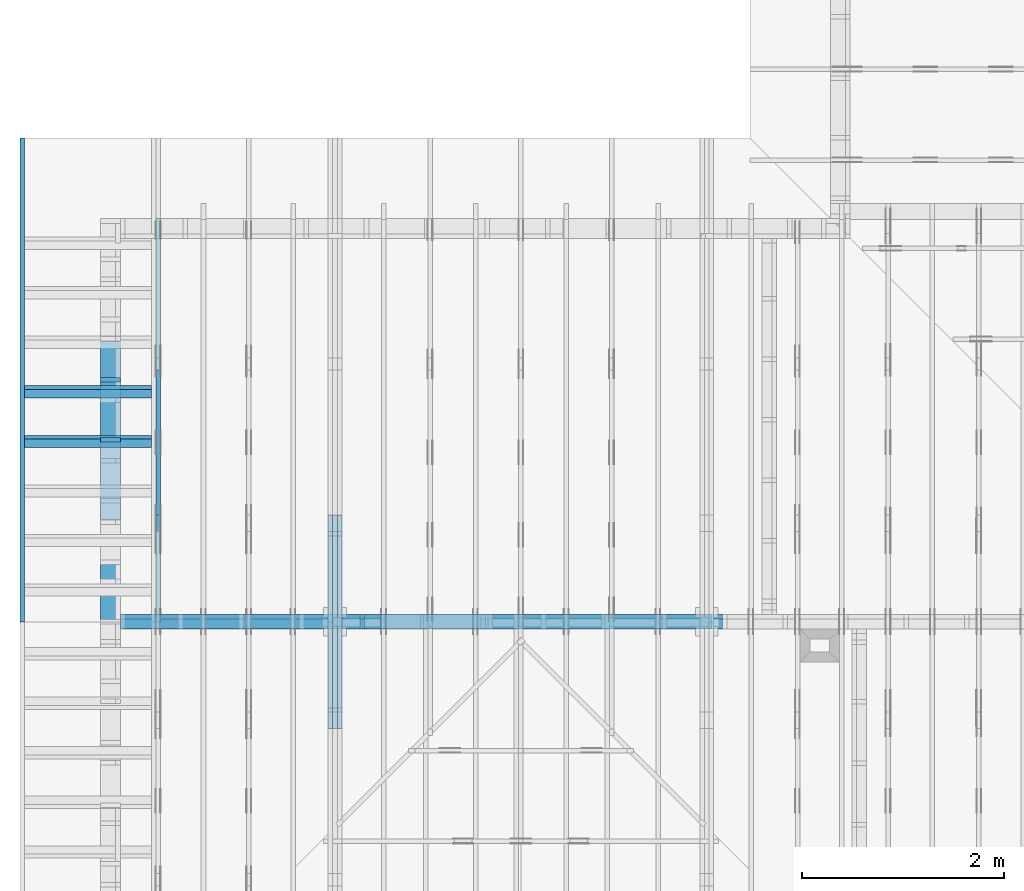
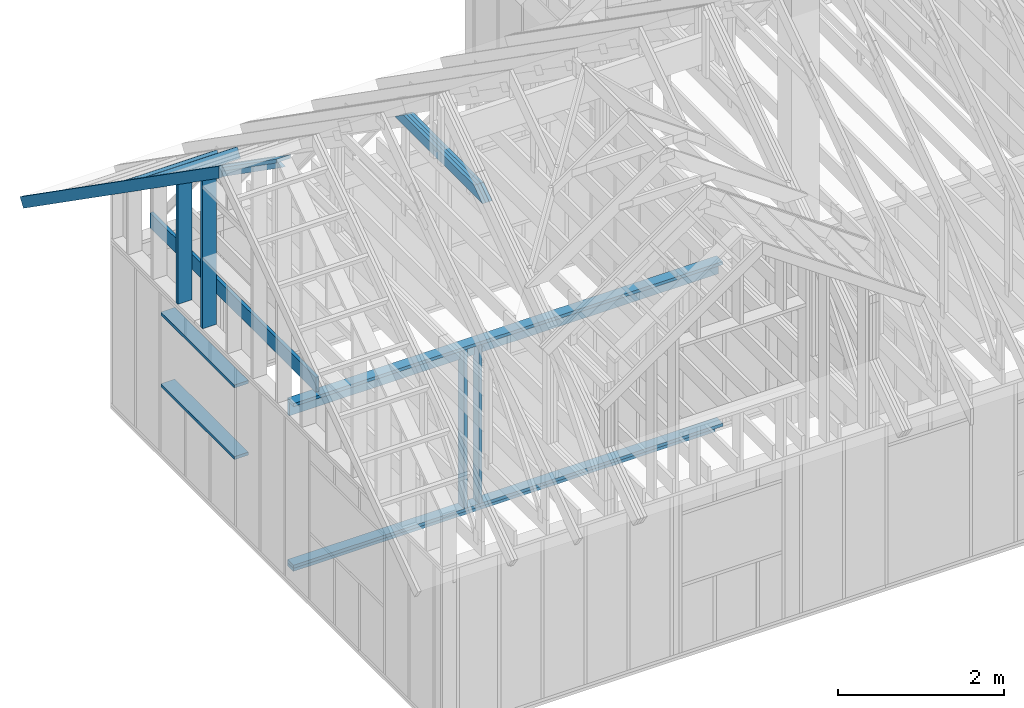
# One storey, part 12 of 70: 19 members, 6 elements without a shape of their own.
"""IFC2X3 building model written with IfcOpenShell, lengths in millimetres."""

from ifc_helpers import new_model, si_unit, frame, origin, origin_with_axes, origin_2d, place, context, project, spatial, faceted_brep, element, aggregate, save


model = new_model("IFC2X3")

# Units and contexts
model_context = context("Model", 3, precision=1e-05, world=origin())
plan_context = context("Plan", 2, precision=1e-05, world=origin_2d())
ifc_project = project(units=[si_unit("LENGTHUNIT", "METRE", prefix="MILLI"), si_unit("AREAUNIT", "SQUARE_METRE"), si_unit("VOLUMEUNIT", "CUBIC_METRE"), si_unit("SOLIDANGLEUNIT", "STERADIAN"), si_unit("PLANEANGLEUNIT", "RADIAN"), si_unit("MASSUNIT", "GRAM"), si_unit("TIMEUNIT", "SECOND"), si_unit("THERMODYNAMICTEMPERATUREUNIT", "DEGREE_CELSIUS"), si_unit("LUMINOUSINTENSITYUNIT", "LUMEN")], contexts=[model_context, plan_context])

# Site, building, storey
site_placement = place(None, origin_with_axes())
site = spatial("IfcSite", under=ifc_project, at=site_placement, CompositionType="ELEMENT")
building_placement = place(site_placement, origin_with_axes())
building = spatial("IfcBuilding", under=site, at=building_placement, Name="Layout 1", CompositionType="ELEMENT")
storey_placement = place(building_placement, origin_with_axes())
storey = spatial("IfcBuildingStorey", under=building, at=storey_placement, Name="Storey 1", CompositionType="ELEMENT", Elevation=0.0)

# Assembly, members
assembly_1_placement = place(storey_placement, frame((1969.9999999999982, 8000.000000000001, 1.1021457184401395e-14), z_axis=(-1.0, 1.836909530733566e-16, 6.123031769111886e-17), x_axis=(-1.836909530733566e-16, -1.0, 0.0)))
assembly_1 = element("IfcElementAssembly", 1, at=assembly_1_placement, inside=storey, Name="T11", AssemblyPlace="FACTORY", PredefinedType="TRUSS")
member_1_placement = place(assembly_1_placement, frame((5060.798502586593, 2964.999999998785, -90.0), z_axis=(0.0, 0.0, 1.0), x_axis=(-1.0, 1.2246063538223773e-16, 0.0)))
member_1 = element("IfcMember", 2, at=member_1_placement, Name="C1", context=model_context, shape_type="Brep", body=[
    faceted_brep([(2121.597005175296, 145.00000000000728, 45.0), (0.0, 145.00000000000728, 45.0), (207.08146097743884, 0.0, 45.0), (1914.5155441979737, 0.0, 45.0), (0.0, 145.00000000000728, 0.0), (2121.597005175296, 145.00000000000728, 2.5981211727881944e-13), (1914.5155441979737, 0.0, 2.3445278999165447e-13), (207.08146097743884, 0.0, 2.5359327287179227e-14), (207.08146097743878, -7.105427357601002e-14, 3.1554436208840472e-30), (207.08146097743878, -7.105427357601002e-14, 45.0), (1.4210854715202004e-14, 145.00000000000728, 45.0), (1.4210854715202004e-14, 145.00000000000728, 0.0), (1914.5155441979737, 7.26803319922997e-12, 4.8521444511629875e-31), (1914.5155441979737, 7.27078856352607e-12, 45.0), (207.08146097743884, 1.898228698049977e-15, 45.0), (207.08146097743884, -8.571355980503717e-16, 5.248268497299439e-32), (2121.597005175296, 145.00000000000728, 0.0), (2121.597005175296, 145.00000000000728, 45.0), (1914.515544197974, 7.389644451905042e-12, 45.0), (1914.515544197974, 7.389644451905042e-12, 1.262177448353619e-29), (0.0, 145.00000000000728, 0.0), (-1.6871183120499046e-31, 145.00000000000728, 45.0), (2121.597005175296, 145.00000000000713, 45.0), (2121.597005175296, 145.00000000000713, -7.888609052210118e-30)], [[[0, 1, 2, 3]], [[4, 5, 6, 7]], [[8, 9, 10, 11]], [[12, 13, 14, 15]], [[16, 17, 18, 19]], [[20, 21, 22, 23]]]),
])
member_2_placement = place(assembly_1_placement, frame((5060.798502586593, 2964.999999998785, -135.0), z_axis=(0.0, 0.0, 1.0), x_axis=(-1.0, 1.2246063538223773e-16, 0.0)))
member_2 = element("IfcMember", 3, at=member_2_placement, Name="C1", context=model_context, shape_type="Brep", body=[
    faceted_brep([(2121.597005175296, 145.00000000000728, 45.0), (0.0, 145.00000000000728, 45.0), (207.08146097743884, 0.0, 45.0), (1914.5155441979737, 0.0, 45.0), (0.0, 145.00000000000728, 0.0), (2121.597005175296, 145.00000000000728, 2.5981211727881944e-13), (1914.5155441979737, 0.0, 2.3445278999165447e-13), (207.08146097743884, 0.0, 2.5359327287179227e-14), (207.08146097743878, -7.105427357601002e-14, 3.1554436208840472e-30), (207.08146097743878, -7.105427357601002e-14, 45.0), (1.4210854715202004e-14, 145.00000000000728, 45.0), (1.4210854715202004e-14, 145.00000000000728, 0.0), (1914.5155441979737, 7.26803319922997e-12, 4.8521444511629875e-31), (1914.5155441979737, 7.27078856352607e-12, 45.0), (207.08146097743884, 1.898228698049977e-15, 45.0), (207.08146097743884, -8.571355980503717e-16, 5.248268497299439e-32), (2121.597005175296, 145.00000000000728, 0.0), (2121.597005175296, 145.00000000000728, 45.0), (1914.515544197974, 7.389644451905042e-12, 45.0), (1914.515544197974, 7.389644451905042e-12, 1.262177448353619e-29), (0.0, 145.00000000000728, 0.0), (-1.6871183120499046e-31, 145.00000000000728, 45.0), (2121.597005175296, 145.00000000000713, 45.0), (2121.597005175296, 145.00000000000713, -7.888609052210118e-30)], [[[0, 1, 2, 3]], [[4, 5, 6, 7]], [[8, 9, 10, 11]], [[12, 13, 14, 15]], [[16, 17, 18, 19]], [[20, 21, 22, 23]]]),
])
member_3_placement = place(assembly_1_placement, frame((5060.798502586593, 2964.999999998785, -180.0), z_axis=(0.0, 0.0, 1.0), x_axis=(-1.0, 1.2246063538223773e-16, 0.0)))
member_3 = element("IfcMember", 4, at=member_3_placement, Name="C1", context=model_context, shape_type="Brep", body=[
    faceted_brep([(2121.597005175296, 145.00000000000728, 45.0), (0.0, 145.00000000000728, 45.0), (207.08146097743884, 0.0, 45.0), (1914.5155441979737, 0.0, 45.0), (0.0, 145.00000000000728, 0.0), (2121.597005175296, 145.00000000000728, 2.5981211727881944e-13), (1914.5155441979737, 0.0, 2.3445278999165447e-13), (207.08146097743884, 0.0, 2.5359327287179227e-14), (207.08146097743878, -7.105427357601002e-14, 3.1554436208840472e-30), (207.08146097743878, -7.105427357601002e-14, 45.0), (1.4210854715202004e-14, 145.00000000000728, 45.0), (1.4210854715202004e-14, 145.00000000000728, 0.0), (1914.5155441979737, 7.26803319922997e-12, 4.8521444511629875e-31), (1914.5155441979737, 7.27078856352607e-12, 45.0), (207.08146097743884, 1.898228698049977e-15, 45.0), (207.08146097743884, -8.571355980503717e-16, 5.248268497299439e-32), (2121.597005175296, 145.00000000000728, 0.0), (2121.597005175296, 145.00000000000728, 45.0), (1914.515544197974, 7.389644451905042e-12, 45.0), (1914.515544197974, 7.389644451905042e-12, 1.262177448353619e-29), (0.0, 145.00000000000728, 0.0), (-1.6871183120499046e-31, 145.00000000000728, 45.0), (2121.597005175296, 145.00000000000713, 45.0), (2121.597005175296, 145.00000000000713, -7.888609052210118e-30)], [[[0, 1, 2, 3]], [[4, 5, 6, 7]], [[8, 9, 10, 11]], [[12, 13, 14, 15]], [[16, 17, 18, 19]], [[20, 21, 22, 23]]]),
])
aggregate(assembly_1, [member_1, member_2, member_3])

assembly_2_placement = place(storey_placement, frame((304.9999999999989, 8000.000000000001, 1.3776821480501744e-15), z_axis=(-1.0, 1.836909530733566e-16, 6.123031769111886e-17), x_axis=(-1.836909530733566e-16, -1.0, 0.0)))
assembly_2 = element("IfcElementAssembly", 5, at=assembly_2_placement, inside=storey, Name="T2", AssemblyPlace="FACTORY", PredefinedType="TRUSS")
member_4_placement = place(assembly_2_placement, frame((3999.9999999999995, 220.0, -45.0), z_axis=(0.0, 0.0, 1.0), x_axis=(-1.0, 1.2246063538223773e-16, 0.0)))
member_4 = element("IfcMember", 6, at=member_4_placement, Name="B3", context=model_context, shape_type="Brep", body=[
    faceted_brep([(3999.9999999999995, 220.00000000000048, 45.0), (0.0, 220.00000000000048, 45.0), (0.0, 0.0, 45.0), (4000.0, 0.0, 45.0), (0.0, 220.00000000000048, 0.0), (3999.9999999999995, 220.00000000000048, 4.898425415289508e-13), (4000.0, 0.0, 4.898425415289509e-13), (0.0, 0.0, 0.0), (0.0, 0.0, 0.0), (2.755364296100349e-15, -3.3742366240998092e-31, 45.0), (2.969670408019265e-14, 220.0, 45.0), (2.69413397840923e-14, 220.0, -1.6496267940043512e-30), (4000.0, -7.347638122934264e-13, 7.457441671638533e-29), (4000.0, -7.32008447997326e-13, 45.0), (5.061354936149714e-31, 2.755364296100349e-15, 45.0), (0.0, 0.0, 0.0), (4000.0, 220.00000000000048, 5.048709793414476e-29), (4000.0, 220.00000000000048, 45.0), (4000.0, 4.831690603168681e-13, 45.0), (4000.0, 4.831690603168681e-13, 0.0), (0.0, 220.0, 0.0), (0.0, 220.0, 45.0), (3999.9999999999995, 220.00000000000065, 45.0), (3999.9999999999995, 220.00000000000065, 9.466330862652142e-30)], [[[0, 1, 2, 3]], [[4, 5, 6, 7]], [[8, 9, 10, 11]], [[12, 13, 14, 15]], [[16, 17, 18, 19]], [[20, 21, 22, 23]]]),
])
member_5_placement = place(assembly_2_placement, frame((1500.0000000042137, 1635.2479181251456, -45.0), z_axis=(0.0, 0.0, 1.0), x_axis=(0.8191520442886182, 0.57357643635158, 0.0)))
member_5 = element("IfcMember", 7, at=member_5_placement, Name="SC5", context=model_context, shape_type="Brep", body=[
    faceted_brep([(1858.4707597648467, 145.0000000027453, 45.0), (101.53009304262741, 145.0000000027453, 45.0), (0.0, 4.505750439420808e-09, 45.0), (2065.552220746341, 4.505750439420808e-09, 45.0), (101.53009304262741, 145.0000000027453, 1.2433439704417867e-14), (1858.4707597648467, 145.0000000027453, 2.275895100801132e-13), (2065.552220746341, 4.505750439420808e-09, 2.5294883736778907e-13), (0.0, 4.505750439420808e-09, 0.0), (5.1128441160023706e-15, 4.505746859368817e-09, -3.82176998409612e-31), (7.369906411908836e-15, 4.505745278956782e-09, 45.0), (101.5300930426274, 145.0000000071184, 45.0), (101.5300930426274, 145.0000000071184, 1.224891444630282e-30), (2065.552220746341, -3.5477999352162224e-13, 2.172329171380478e-29), (2065.552220746341, -3.520246292255219e-13, 45.0), (6.010964676742231e-27, 4.505753194785104e-09, 45.0), (0.0, 4.505750439420808e-09, 0.0), (1858.4707597648467, 145.0000000027453, -1.262177448353619e-29), (1858.4707597648467, 145.0000000027453, 45.0), (2065.552220746341, 1.1368683772161603e-13, 45.0), (2065.552220746341, 1.1368683772161603e-13, -1.262177448353619e-29), (101.53009304262741, 145.0000000071184, 0.0), (101.53009304262741, 145.0000000071184, 45.0), (1858.4707597648467, 145.00000000274542, 45.0), (1858.4707597648467, 145.00000000274542, 6.310887241768095e-30)], [[[0, 1, 2, 3]], [[4, 5, 6, 7]], [[8, 9, 10, 11]], [[12, 13, 14, 15]], [[16, 17, 18, 19]], [[20, 21, 22, 23]]]),
])
aggregate(assembly_2, [member_4, member_5])

assembly_3_placement = place(storey_placement, frame((-243.55339059327574, 8000.000000000001, -2470.0), z_axis=(-1.0, 1.836909530733566e-16, 6.123031769111886e-17), x_axis=(-1.836909530733566e-16, -1.0, 0.0)))
assembly_3 = element("IfcElementAssembly", 8, at=assembly_3_placement, inside=storey, Name="VE3", AssemblyPlace="FACTORY", PredefinedType="NOTDEFINED")
member_6_placement = place(assembly_3_placement, frame((2987.500000001819, 2154.9999999987776, -195.0), z_axis=(0.0, 0.0, 1.0), x_axis=(-1.0, 1.2246063538223773e-16, 0.0)))
member_6 = element("IfcMember", 9, at=member_6_placement, Name="S17", context=model_context, shape_type="Brep", body=[
    faceted_brep([(1774.9999999999998, 45.00000000001501, 195.0), (0.0, 45.00000000001501, 195.0), (0.0, 0.0, 195.0), (1774.9999999999998, 0.0, 195.0), (0.0, 45.00000000001501, 0.0), (1774.9999999999998, 45.00000000001501, 2.1736762780347194e-13), (1774.9999999999998, 0.0, 2.1736762780347194e-13), (0.0, 0.0, 0.0), (0.0, 0.0, 0.0), (1.1939911949768178e-14, -1.462169203776584e-30, 195.0), (1.745064054197066e-14, 45.00000000001455, 195.0), (5.51072859220248e-15, 45.00000000001455, -3.3742366241009005e-31), (1774.9999999999998, -3.260514417052079e-13, 4.7808558123230106e-29), (1774.9999999999998, -3.141115297554397e-13, 195.0), (2.193253805664876e-30, 1.1939911949768178e-14, 195.0), (0.0, 0.0, 0.0), (1774.9999999999998, 45.00000000001501, 0.0), (1774.9999999999998, 45.00000000001501, 195.0), (1774.9999999999998, 4.547473508864641e-13, 195.0), (1774.9999999999998, 4.547473508864641e-13, 0.0), (0.0, 45.00000000001455, 0.0), (1.5777218104420236e-30, 45.00000000001454, 195.0), (1774.9999999999998, 45.00000000001482, 195.0), (1774.9999999999998, 45.000000000014836, -1.064962222048366e-29)], [[[0, 1, 2, 3]], [[4, 5, 6, 7]], [[8, 9, 10, 11]], [[12, 13, 14, 15]], [[16, 17, 18, 19]], [[20, 21, 22, 23]]]),
])
member_7_placement = place(assembly_3_placement, frame((1212.500000001819, 1055.0, -195.0), z_axis=(0.0, 0.0, 1.0), x_axis=(1.0, 0.0, 0.0)))
member_7 = element("IfcMember", 10, at=member_7_placement, Name="S17", context=model_context, shape_type="Brep", body=[
    faceted_brep([(1775.0, 45.0, 195.0), (0.0, 45.0, 195.0), (0.0, 0.0, 195.0), (1775.0, 0.0, 195.0), (0.0, 45.0, 0.0), (1775.0, 45.0, 2.1736762780347196e-13), (1775.0, 0.0, 2.1736762780347196e-13), (0.0, 0.0, 0.0), (0.0, 0.0, 0.0), (1.1939911949768178e-14, -1.462169203776584e-30, 195.0), (1.7450640541968876e-14, 45.0, 195.0), (5.510728592200698e-15, 45.0, -3.3742366240998092e-31), (1775.0, -3.2605144170520794e-13, 1.9964233359257205e-29), (1775.0, -3.1411152975543977e-13, 195.0), (2.193253805664876e-30, 1.1939911949768178e-14, 195.0), (0.0, 0.0, 0.0), (1775.0, 45.0, 0.0), (1775.0, 45.0, 195.0), (1775.0, 0.0, 195.0), (1775.0, 0.0, 0.0), (0.0, 45.0, 0.0), (-7.31084601888292e-31, 44.999999999999986, 195.0), (1775.0, 44.99999999999988, 195.0), (1775.0, 44.99999999999989, -6.7053176943786e-30)], [[[0, 1, 2, 3]], [[4, 5, 6, 7]], [[8, 9, 10, 11]], [[12, 13, 14, 15]], [[16, 17, 18, 19]], [[20, 21, 22, 23]]]),
])
aggregate(assembly_3, [member_6, member_7])

assembly_4_placement = place(storey_placement, frame((-48.55339059327645, 2.2546681725408788e-11, 1.1939911949768178e-14), z_axis=(1.0, 1.156240088482502e-13, 6.123031769111886e-17), x_axis=(-1.156240088482502e-13, 1.0, 0.0)))
assembly_4 = element("IfcElementAssembly", 11, at=assembly_4_placement, inside=storey, Name="VEg1", AssemblyPlace="FACTORY", PredefinedType="NOTDEFINED")
member_8_placement = place(assembly_4_placement, frame((3974.1890603636393, 3586.9559954754677, -195.00000000000003), z_axis=(0.0, 0.0, 1.0), x_axis=(0.8191520442889916, -0.5735764363510465, 0.0)))
member_8 = element("IfcMember", 12, at=member_8_placement, Name="P6", context=model_context, shape_type="Brep", body=[
    faceted_brep([(4883.098355046159, 45.00000000051023, 195.0), (0.0, 45.00000000051023, 195.0), (31.509339219794583, 4.756657290272415e-10, 195.0), (4914.607694265953, 4.756657290272415e-10, 195.0), (0.0, 45.00000000051023, 0.0), (4883.098355046159, 45.00000000051023, 5.979873271929125e-13), (4914.607694265953, 4.756657290272415e-10, 6.018459808942429e-13), (31.509339219794583, 4.756657290272415e-10, 3.858653701330508e-15), (31.509339219794576, 4.756639526704021e-10, 1.9721522630525295e-31), (31.509339219794587, 4.756710580977597e-10, 195.0), (2.1316282072803006e-14, 45.0000000009859, 195.0), (1.0658141036401503e-14, 45.00000000098589, -5.9164567891575885e-31), (4914.607694265953, 2.042018918645736e-12, -1.2503346711995083e-28), (4914.607694265953, 2.053958830595504e-12, 195.0), (31.509339219794583, 4.756907610659292e-10, 195.0), (31.509339219794583, 4.756788211539795e-10, -8.016350794158172e-31), (4883.098355046159, 45.00000000051068, 5.048709793414476e-29), (4883.098355046159, 45.00000000051068, 195.0), (4914.607694265953, 4.547473508864641e-13, 195.0), (4914.607694265953, 4.547473508864641e-13, 5.048709793414476e-29), (0.0, 45.00000000098589, 0.0), (-8.077935669463161e-28, 45.00000000098588, 195.0), (4883.098355046159, 45.000000000510674, 195.0), (4883.098355046159, 45.00000000051069, 2.800456213534592e-29)], [[[0, 1, 2, 3]], [[4, 5, 6, 7]], [[8, 9, 10, 11]], [[12, 13, 14, 15]], [[16, 17, 18, 19]], [[20, 21, 22, 23]]]),
])
member_9_placement = place(assembly_4_placement, frame((6422.500000008281, 45.0, -195.0), z_axis=(0.0, 0.0, 1.0), x_axis=(-3.8285889215894375e-16, 1.0, 0.0)))
member_9 = element("IfcMember", 13, at=member_9_placement, Name="S16", context=model_context, shape_type="Brep", body=[
    faceted_brep([(1859.1395588746745, 45.00000000001455, 195.0), (1.4210854715202004e-14, 45.00000000001455, 195.0), (0.0, 4.4537955545820296e-09, 195.0), (1827.6302196552206, 4.4537955545820296e-09, 195.0), (1.4210854715202004e-14, 45.00000000001455, 1.7402702977483063e-30), (1859.1395588746745, 45.00000000001455, 2.276714116440458e-13), (1827.6302196552206, 4.4537955545820296e-09, 2.23812757942757e-13), (0.0, 4.4537955545820296e-09, 0.0), (-8.610801843216705e-25, 4.4537955545820296e-09, 5.272421324354307e-41), (1.1939911948907099e-14, 4.4537955545820296e-09, 195.0), (1.745064054110958e-14, 45.00000000446835, 195.0), (5.510728591341399e-15, 45.00000000446835, 5.327114865167873e-31), (1827.6302196552206, 8.529366908340968e-13, -5.222558455021902e-29), (1827.6302196552206, 8.648766027838649e-13, 195.0), (2.909108319763153e-26, 4.453807494493979e-09, 195.0), (0.0, 4.4537955545820296e-09, 0.0), (1859.139558874675, 45.00000000001421, 2.524354896707238e-29), (1859.139558874675, 45.00000000001421, 195.0), (1827.630219655221, -3.410605131648481e-13, 195.0), (1827.630219655221, -3.410605131648481e-13, 2.524354896707238e-29), (1.4210854715202004e-14, 45.00000000446835, 0.0), (1.4210854715176154e-14, 45.00000000446833, 195.0), (1859.1395588746745, 45.000000000014396, 195.0), (1859.1395588746745, 45.0000000000144, -9.071900410041636e-30)], [[[0, 1, 2, 3]], [[4, 5, 6, 7]], [[8, 9, 10, 11]], [[12, 13, 14, 15]], [[16, 17, 18, 19]], [[20, 21, 22, 23]]]),
])
member_10_placement = place(assembly_4_placement, frame((5782.4999999990105, 2320.7630441160145, -195.0), z_axis=(0.0, 0.0, 1.0), x_axis=(-1.836909530733566e-16, -1.0, 0.0)))
member_10 = element("IfcMember", 14, at=member_10_placement, Name="S12", context=model_context, shape_type="Brep", body=[
    faceted_brep([(2275.7630441160145, 45.0, 195.0), (31.509339219439426, 45.0, 195.0), (0.0, 0.0, 195.0), (2275.7630441160145, 0.0, 195.0), (31.509339219439426, 45.0, 3.8586537012870146e-15), (2275.7630441160145, 45.0, 2.7869138836186266e-13), (2275.7630441160145, 0.0, 2.7869138836186266e-13), (0.0, 0.0, 0.0), (0.0, 0.0, 0.0), (9.78060328228291e-15, -6.848452146493666e-15, 195.0), (31.509339219439447, 44.99999999999999, 195.0), (31.509339219439436, 45.0, -3.944304526105059e-31), (2275.7630441160145, -4.1803708254279397e-13, 2.5596543370763753e-29), (2275.7630441160145, -4.060971705930258e-13, 195.0), (2.193253805664876e-30, 1.1939911949768178e-14, 195.0), (0.0, 0.0, 0.0), (2275.7630441160145, 45.0, 0.0), (2275.7630441160145, 45.0, 195.0), (2275.7630441160145, 0.0, 195.0), (2275.7630441160145, 0.0, 0.0), (31.509339219439426, 45.0, 0.0), (31.509339219439426, 44.999999999999986, 195.0), (2275.7630441160145, 44.99999999999985, 195.0), (2275.7630441160145, 44.99999999999986, -8.67746995743113e-30)], [[[0, 1, 2, 3]], [[4, 5, 6, 7]], [[8, 9, 10, 11]], [[12, 13, 14, 15]], [[16, 17, 18, 19]], [[20, 21, 22, 23]]]),
])
aggregate(assembly_4, [member_8, member_9, member_10])

assembly_5_placement = place(storey_placement, frame((-48.55339059327651, 3927.500000000001, -2470.0), z_axis=(0.0, -1.0, 6.123031769111886e-17), x_axis=(1.0, 0.0, 0.0)))
assembly_5 = element("IfcElementAssembly", 15, at=assembly_5_placement, inside=storey, Name="VE8", AssemblyPlace="FACTORY", PredefinedType="NOTDEFINED")
member_11_placement = place(assembly_5_placement, frame((1.457281561048629e-13, 2425.0, -145.0), z_axis=(0.0, 0.0, 1.0), x_axis=(1.0, 0.0, 0.0)))
member_11 = element("IfcMember", 16, at=member_11_placement, Name="P13", context=model_context, shape_type="Brep", body=[
    faceted_brep([(5979.999999999998, 45.0, 145.0), (2.755364296100349e-15, 45.0, 145.0), (0.0, 0.0, 145.0), (5979.999999999998, 0.0, 145.0), (2.755364296100349e-15, 45.0, 3.3742366240998092e-31), (5979.999999999998, 45.0, 7.323145995857814e-13), (5979.999999999998, 0.0, 7.323145995857814e-13), (0.0, 0.0, 0.0), (-3.944304526105059e-31, 4.830220384078616e-47, 2.415110192039308e-47), (8.878396065212235e-15, -1.0872540233210496e-30, 145.0), (1.4389124657412933e-14, 45.0, 145.0), (5.510728592200698e-15, 45.0, -1.6871183120499044e-31), (5979.999999999998, -1.098471899378672e-12, 6.725978337372284e-29), (5979.999999999998, -1.0895935033134598e-12, 145.0), (1.6308810349815745e-30, 8.878396065212235e-15, 145.0), (0.0, 0.0, 0.0), (5979.999999999998, 45.0, 0.0), (5979.999999999998, 45.0, 145.0), (5979.999999999998, 0.0, 145.0), (5979.999999999998, 0.0, 0.0), (2.755364296100349e-15, 45.0, 0.0), (2.7553642961003484e-15, 44.99999999999999, 145.0), (5979.999999999998, 44.99999999999962, 145.0), (5979.999999999998, 44.99999999999963, -2.2482535798798836e-29)], [[[0, 1, 2, 3]], [[4, 5, 6, 7]], [[8, 9, 10, 11]], [[12, 13, 14, 15]], [[16, 17, 18, 19]], [[20, 21, 22, 23]]]),
])
member_12_placement = place(assembly_5_placement, frame((5979.999999999999, 90.0, -145.0), z_axis=(0.0, 0.0, 1.0), x_axis=(-1.0, 1.2246063538223773e-16, 0.0)))
member_12 = element("IfcMember", 17, at=member_12_placement, Name="P13", context=model_context, shape_type="Brep", body=[
    faceted_brep([(5979.999999999999, 45.00000000000074, 145.0), (0.0, 45.00000000000074, 145.0), (0.0, 0.0, 145.0), (5979.999999999999, 0.0, 145.0), (0.0, 45.00000000000074, 0.0), (5979.999999999999, 45.00000000000074, 7.323145995857815e-13), (5979.999999999999, 0.0, 7.323145995857815e-13), (0.0, 0.0, 0.0), (0.0, 0.0, 0.0), (8.878396065212235e-15, -1.0872540233210496e-30, 145.0), (1.4389124657412933e-14, 45.00000000000001, 145.0), (5.5107285922006985e-15, 45.00000000000001, -3.3742366240998097e-31), (5979.999999999999, -1.0984718993786722e-12, 1.1250681111517883e-28), (5979.999999999999, -1.08959350331346e-12, 145.0), (1.6308810349815745e-30, 8.878396065212235e-15, 145.0), (0.0, 0.0, 0.0), (5979.999999999999, 45.00000000000074, 0.0), (5979.999999999999, 45.00000000000074, 145.0), (5979.999999999999, 7.389644451905042e-13, 145.0), (5979.999999999999, 7.389644451905042e-13, 0.0), (0.0, 45.00000000000001, 0.0), (1.5777218104420236e-30, 45.0, 145.0), (5979.999999999999, 45.00000000000096, 145.0), (5979.999999999999, 45.000000000000966, 1.3805065841367707e-29)], [[[0, 1, 2, 3]], [[4, 5, 6, 7]], [[8, 9, 10, 11]], [[12, 13, 14, 15]], [[16, 17, 18, 19]], [[20, 21, 22, 23]]]),
])
member_13_placement = place(assembly_5_placement, frame((1.3378824415499132e-13, 2229.9999999981374, -145.0), z_axis=(0.0, 0.0, 1.0), x_axis=(1.0, 0.0, 0.0)))
member_13 = element("IfcMember", 18, at=member_13_placement, Name="L1", context=model_context, shape_type="Brep", body=[
    faceted_brep([(5979.999999999998, 195.00000000186265, 45.0), (1.1939911949871576e-14, 195.00000000186265, 45.0), (0.0, 0.0, 45.0), (5979.999999999998, 0.0, 45.0), (1.1939911949871576e-14, 195.00000000186265, 1.4621692037892461e-30), (5979.999999999998, 195.00000000186265, 7.323145995857814e-13), (5979.999999999998, 0.0, 7.323145995857814e-13), (0.0, 0.0, 0.0), (0.0, 0.0, 0.0), (2.755364296100349e-15, -3.3742366240998092e-31, 45.0), (2.6635188195864806e-14, 195.00000000186265, 45.0), (2.3879823899764457e-14, 195.00000000186265, -7.310846018959277e-31), (5979.999999999998, 1.8631702674827898e-09, -3.2153157385103216e-29), (5979.999999999998, 1.863173022847086e-09, 45.0), (-8.584804067855881e-28, 2.755364296100349e-15, 45.0), (0.0, 0.0, 0.0), (5979.999999999998, 195.00000000186265, 0.0), (5979.999999999998, 195.00000000186265, 45.0), (5979.999999999998, 1.862645149230957e-09, 45.0), (5979.999999999998, 1.862645149230957e-09, 0.0), (1.1939911949871576e-14, 195.00000000186265, 0.0), (1.1939911949871576e-14, 195.00000000186265, 45.0), (5979.999999999998, 195.00000000186228, 45.0), (5979.999999999998, 195.00000000186228, -2.208810534618833e-29)], [[[0, 1, 2, 3]], [[4, 5, 6, 7]], [[8, 9, 10, 11]], [[12, 13, 14, 15]], [[16, 17, 18, 19]], [[20, 21, 22, 23]]]),
])
member_14_placement = place(assembly_5_placement, frame((5873.553390593276, 45.00000000000073, -145.0), z_axis=(0.0, 0.0, 1.0), x_axis=(-1.0, 1.2246063538223773e-16, 0.0)))
member_14 = element("IfcMember", 19, at=member_14_placement, Name="P14", context=model_context, shape_type="Brep", body=[
    faceted_brep([(5873.553390593276, 45.00000000000145, 145.0), (0.0, 45.00000000000145, 145.0), (0.0, 0.0, 145.0), (5873.553390593276, 0.0, 145.0), (0.0, 45.00000000000145, 0.0), (5873.553390593276, 45.00000000000145, 7.192790801635493e-13), (5873.553390593276, 0.0, 7.192790801635493e-13), (0.0, 0.0, 0.0), (0.0, 0.0, 0.0), (8.878396065212235e-15, -1.0872540233210496e-30, 145.0), (1.4389124657412933e-14, 45.00000000000001, 145.0), (5.5107285922006985e-15, 45.00000000000001, -3.3742366240998097e-31), (5873.553390593276, -1.078918620245324e-12, 1.5481631506564843e-28), (5873.553390593276, -1.0700402241801118e-12, 145.0), (1.6308810349815745e-30, 8.878396065212235e-15, 145.0), (0.0, 0.0, 0.0), (5873.553390593276, 45.00000000000145, 0.0), (5873.553390593276, 45.00000000000145, 145.0), (5873.553390593276, 1.4495071809506044e-12, 145.0), (5873.553390593276, 1.4495071809506044e-12, 0.0), (0.0, 45.00000000000001, 0.0), (1.5777218104420236e-30, 45.0, 145.0), (5873.553390593276, 45.000000000000945, 145.0), (5873.553390593276, 45.00000000000095, -3.0371144851008955e-29)], [[[0, 1, 2, 3]], [[4, 5, 6, 7]], [[8, 9, 10, 11]], [[12, 13, 14, 15]], [[16, 17, 18, 19]], [[20, 21, 22, 23]]]),
])
member_15_placement = place(assembly_5_placement, frame((2377.500000001834, 2425.0, -145.0), z_axis=(0.0, 0.0, 1.0), x_axis=(-1.836909530733566e-16, -1.0, 0.0)))
member_15 = element("IfcMember", 20, at=member_15_placement, Name="S42", context=model_context, shape_type="Brep", body=[
    faceted_brep([(0.0, 44.999999999999545, 45.0), (195.00000000186265, 44.999999999999545, 45.00000000000002), (195.00000000186265, 1.4097167877480388e-11, 45.00000000000002), (0.0, 1.4097167877480388e-11, 45.0), (195.00000000186265, 1.2732925824820995e-11, 0.0), (195.00000000186265, 1.2732925824820995e-11, 45.0), (195.00000000186265, 44.999999999999545, 45.0), (195.00000000186265, 44.999999999999545, 0.0), (2.7553642961020753e-15, 1.4097167877480388e-11, 45.0), (8.878396065213961e-15, 1.4097167877480388e-11, 145.0), (1.4389124657412876e-14, 44.999999999999545, 145.0), (8.26609288830099e-15, 44.999999999999545, 45.0), (2335.0, 1.36682495020541e-11, 2.626280839091018e-29), (2335.0, 1.3677127898119312e-11, 145.0), (1.6308810349815745e-30, 1.41060462735456e-11, 145.0), (5.061354936149714e-31, 1.4099923241776488e-11, 45.0), (195.00000000186265, 1.4064103505926841e-11, 45.0), (195.00000000186265, 1.406134814163074e-11, 2.193253805685862e-30), (-1.6871183120499046e-31, 44.999999999999545, 45.0), (-5.436270116605248e-31, 44.99999999999954, 145.0), (2335.0, 44.999999999999396, 145.0), (2335.0, 44.9999999999994, -8.67746995743113e-30), (195.00000000186265, 44.99999999999953, -7.888609052210118e-31), (195.00000000186265, 44.99999999999953, 45.0), (2335.0, 45.0, 2.842170943040401e-14), (2335.0, 45.0, 145.0), (2335.0, 0.0, 145.0), (2335.0, 0.0, 0.0), (2335.0, 45.0, 145.0), (0.0, 45.0, 145.0), (0.0, 1.4097167877480388e-11, 145.0), (2335.0, 1.4097167877480388e-11, 145.0), (195.00000000186265, 44.999999999999545, 2.3879823899764457e-14), (2335.0, 44.999999999999545, 2.859455836175251e-13), (2335.0, 0.0, 2.859455836175251e-13), (195.00000000186265, 0.0, 2.3879823899764457e-14)], [[[0, 1, 2, 3]], [[4, 5, 6, 7]], [[8, 9, 10, 11]], [[12, 13, 14, 15, 16, 17]], [[18, 19, 20, 21, 22, 23]], [[24, 25, 26, 27]], [[28, 29, 30, 31]], [[32, 33, 34, 35]]]),
])
member_16_placement = place(assembly_5_placement, frame((2582.3033905951015, 2425.0, -145.0), z_axis=(0.0, 0.0, 1.0), x_axis=(-1.836909530733566e-16, -1.0, 0.0)))
member_16 = element("IfcMember", 21, at=member_16_placement, Name="S42", context=model_context, shape_type="Brep", body=[
    faceted_brep([(0.0, 45.0, 45.0), (195.00000000186265, 45.0, 45.00000000000002), (195.00000000186265, 0.0, 45.00000000000002), (0.0, 0.0, 45.0), (195.00000000186265, 1.3642420526593924e-12, 0.0), (195.00000000186265, 1.3642420526593924e-12, 45.0), (195.00000000186265, 45.000000000001364, 45.0), (195.00000000186265, 45.000000000001364, 0.0), (2.755364296100349e-15, -3.3742366240998092e-31, 45.0), (8.878396065212235e-15, -1.0872540233210496e-30, 145.0), (1.4389124657412933e-14, 45.0, 145.0), (8.266092888301046e-15, 45.0, 45.0), (2335.0, -4.2891837542628763e-13, 2.626280839091018e-29), (2335.0, -4.200399793610754e-13, 145.0), (1.6308810349815745e-30, 8.878396065212235e-15, 145.0), (5.061354936149714e-31, 2.755364296100349e-15, 45.0), (195.00000000186265, -3.306437155354634e-14, 45.0), (195.00000000186265, -3.5819735849646686e-14, 2.193253805685826e-30), (-1.6871183120499046e-31, 45.000000000001364, 45.0), (-5.436270116605248e-31, 45.00000000000136, 145.0), (2335.0, 45.000000000001215, 145.0), (2335.0, 45.00000000000122, -8.67746995743113e-30), (195.00000000186265, 45.00000000000135, -7.888609052210118e-31), (195.00000000186265, 45.00000000000135, 45.0), (2335.0, 45.00000000001501, 2.842170943040401e-14), (2335.0, 45.00000000001501, 145.0), (2335.0, 1.5006662579253316e-11, 145.0), (2335.0, 1.5006662579253316e-11, 0.0), (2335.0, 45.00000000001501, 145.0), (0.0, 45.00000000001501, 145.0), (0.0, 0.0, 145.0), (2335.0, 0.0, 145.0), (195.00000000186265, 45.000000000001364, 2.3879823899764457e-14), (2335.0, 45.000000000001364, 2.859455836175251e-13), (2335.0, 1.5006662579253316e-11, 2.859455836175251e-13), (195.00000000186265, 1.5006662579253316e-11, 2.3879823899764457e-14)], [[[0, 1, 2, 3]], [[4, 5, 6, 7]], [[8, 9, 10, 11]], [[12, 13, 14, 15, 16, 17]], [[18, 19, 20, 21, 22, 23]], [[24, 25, 26, 27]], [[28, 29, 30, 31]], [[32, 33, 34, 35]]]),
])
aggregate(assembly_5, [member_11, member_12, member_13, member_14, member_15, member_16])

assembly_6_placement = place(storey_placement, frame((-1043.5533905932762, 8800.000000000002, 439.83396943223045), z_axis=(9.428742447176872e-17, 0.5735764363510464, 0.8191520442889916), x_axis=(-1.153505523095189e-16, -0.8191520442889916, 0.5735764363510464)))
assembly_6 = element("IfcElementAssembly", 22, at=assembly_6_placement, inside=storey, Name="gs1", AssemblyPlace="FACTORY", PredefinedType="TRUSS")
member_17_placement = place(assembly_6_placement, frame((5859.71802605499, 45.0, -145.00000000001148), z_axis=(0.0, 0.0, 1.0), x_axis=(-1.0, 1.2246063538223773e-16, 0.0)))
member_17 = element("IfcMember", 23, at=member_17_placement, Name="T2", context=model_context, shape_type="Brep", body=[
    faceted_brep([(101.53009303919245, 6.638928422026716e-13, 1.3500311979441904e-13), (8.810729923425242e-13, -2.0194839173657902e-28, 145.00000000001188), (8.810729923425242e-13, 45.0, 145.00000000001145), (101.53009303919224, 45.00000000000067, 1.4210854715202004e-14), (5859.718026055004, -1.0763771889471708e-12, 1.1482370609883219e-11), (5859.718026055004, -1.0674987928819585e-12, 145.00000000001148), (1.6308810349817037e-30, 8.878396065212939e-15, 145.00000000001148), (101.53009303920862, -1.8650159555998097e-14, 1.1482370609883219e-11), (101.53009303920862, 45.000000000000014, 1.1494804049587219e-11), (5859.71802605499, 45.000000000000014, 1.2199955402514665e-11), (5859.718026055004, 7.176481631177012e-13, 1.2199955402514667e-11), (101.53009303920862, 7.176481631177012e-13, 1.1494804049587219e-11), (9.094947017729282e-13, 45.00000000000001, 145.00000000001148), (5859.71802605499, 44.999999999999645, 145.00000000001148), (5859.71802605499, 44.99999999999966, 1.1482370609883219e-11), (101.53009303920862, 45.00000000000001, 1.1482370609883219e-11), (5859.718026055004, 45.00000000000072, 1.1510792319313623e-11), (5859.718026055004, 45.00000000000072, 145.00000000001148), (5859.718026055004, 7.247535904753022e-13, 145.00000000001148), (5859.718026055004, 7.247535904753022e-13, 1.1482370609883219e-11), (5859.71802605499, 45.00000000000072, 145.00000000001148), (9.094947017729282e-13, 45.00000000000072, 145.00000000001148), (0.0, 0.0, 145.00000000001148), (5859.718026055004, 0.0, 145.00000000001148)], [[[0, 1, 2, 3]], [[4, 5, 6, 7]], [[8, 9, 10, 11]], [[12, 13, 14, 15]], [[16, 17, 18, 19]], [[20, 21, 22, 23]]]),
])
member_18_placement = place(assembly_6_placement, frame((3044.9999999989814, 45.0, -145.0), z_axis=(0.0, 0.0, 1.0), x_axis=(6.123031769111886e-17, 1.0, 0.0)))
member_18 = element("IfcMember", 24, at=member_18_placement, Name="W4", context=model_context, shape_type="Brep", body=[
    faceted_brep([(1258.5533905932764, 45.00000000001455, 145.0), (0.0, 45.00000000001455, 145.0), (0.0, 0.0, 145.0), (1258.5533905932764, 0.0, 145.0), (0.0, 45.00000000001455, 0.0), (1258.5533905932764, 45.00000000001455, 1.5412324787452224e-13), (1258.5533905932764, 0.0, 1.5412324787452224e-13), (0.0, 0.0, 0.0), (0.0, 0.0, 0.0), (8.878396065212235e-15, -1.0872540233210496e-30, 145.0), (1.4389124657412933e-14, 45.0, 145.0), (5.510728592200698e-15, 45.0, -3.3742366240998092e-31), (1258.5533905932764, -2.3118487181178335e-13, 1.4155523146416086e-29), (1258.5533905932764, -2.2230647574657112e-13, 145.0), (1.6308810349815745e-30, 8.878396065212235e-15, 145.0), (0.0, 0.0, 0.0), (1258.5533905932764, 45.00000000001455, 0.0), (1258.5533905932764, 45.00000000001455, 145.0), (1258.5533905932764, 0.0, 145.0), (1258.5533905932764, 0.0, 0.0), (0.0, 45.0, 0.0), (1.0097419586828951e-28, 44.99999999999999, 145.0), (1258.5533905932764, 45.00000000001472, 145.0), (1258.5533905932764, 45.00000000001474, 1.1044052673094165e-29)], [[[0, 1, 2, 3]], [[4, 5, 6, 7]], [[8, 9, 10, 11]], [[12, 13, 14, 15]], [[16, 17, 18, 19]], [[20, 21, 22, 23]]]),
])
member_19_placement = place(assembly_6_placement, frame((3644.9999999989814, 45.0, -145.0), z_axis=(0.0, 0.0, 1.0), x_axis=(6.123031769111886e-17, 1.0, 0.0)))
member_19 = element("IfcMember", 25, at=member_19_placement, Name="W4", context=model_context, shape_type="Brep", body=[
    faceted_brep([(1258.5533905932764, 45.0, 145.0), (0.0, 45.0, 145.0), (0.0, 0.0, 145.0), (1258.5533905932764, 0.0, 145.0), (0.0, 45.0, 0.0), (1258.5533905932764, 45.0, 1.5412324787452224e-13), (1258.5533905932764, 0.0, 1.5412324787452224e-13), (0.0, 0.0, 0.0), (0.0, 0.0, 0.0), (8.878396065212235e-15, -1.0872540233210496e-30, 145.0), (1.4389124657412933e-14, 45.0, 145.0), (5.510728592200698e-15, 45.0, -3.3742366240998092e-31), (1258.5533905932764, -2.3118487181178335e-13, 1.4155523146416086e-29), (1258.5533905932764, -2.2230647574657112e-13, 145.0), (1.6308810349815745e-30, 8.878396065212235e-15, 145.0), (0.0, 0.0, 0.0), (1258.5533905932764, 45.0, 0.0), (1258.5533905932764, 45.0, 145.0), (1258.5533905932764, 0.0, 145.0), (1258.5533905932764, 0.0, 0.0), (0.0, 45.0, 0.0), (-5.436270116605248e-31, 44.99999999999999, 145.0), (1258.5533905932764, 44.999999999999915, 145.0), (1258.5533905932764, 44.99999999999992, -4.733165431326071e-30)], [[[0, 1, 2, 3]], [[4, 5, 6, 7]], [[8, 9, 10, 11]], [[12, 13, 14, 15]], [[16, 17, 18, 19]], [[20, 21, 22, 23]]]),
])
aggregate(assembly_6, [member_17, member_18, member_19])

save(model, "model.ifc")
